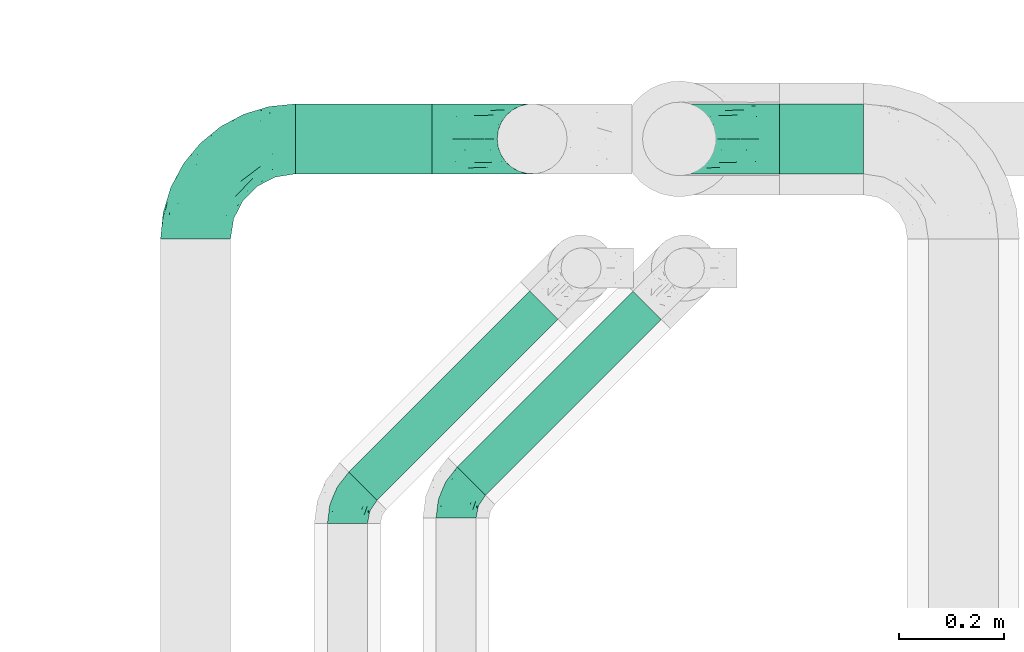
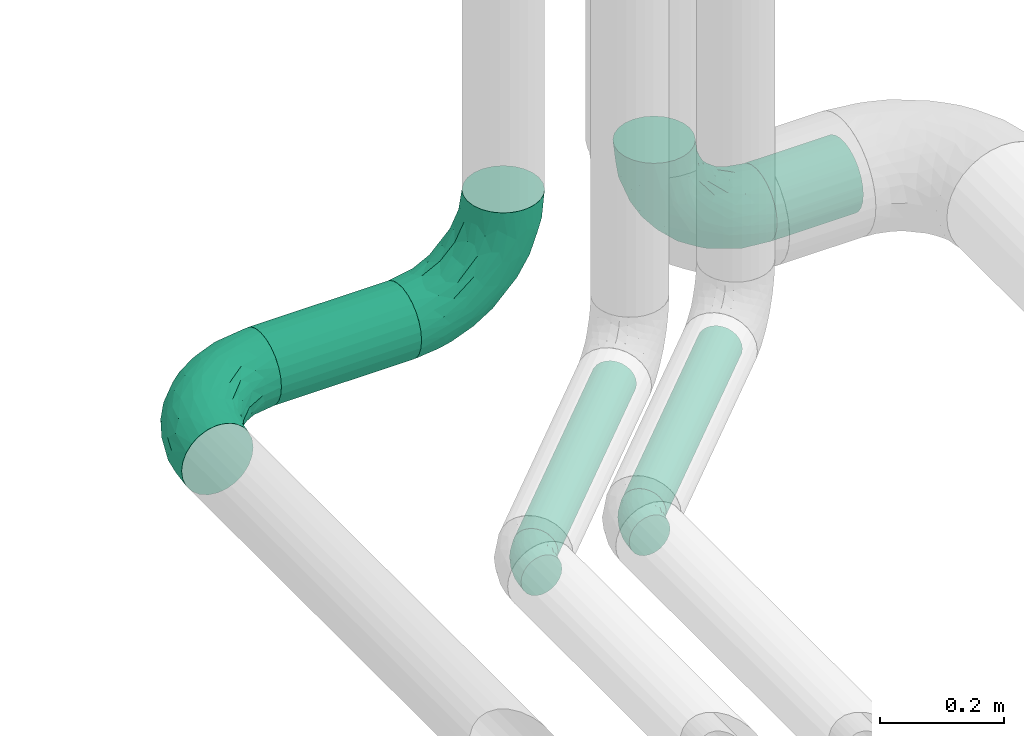
# One storey, part 70 of 93: 5 flow fittings, 4 flow segments.
"""IFC2X3 building model written with IfcOpenShell, lengths in millimetres."""

from ifc_helpers import new_model, entity, si_unit, converted_unit, derived_unit, direction, frame, origin, origin_2d_with_axis, place, context, subcontext, project, spatial, circle, extrude, faceted_brep, source, transform, mapped, material, type_object, type_shapes, element, save


model = new_model("IFC2X3")

# Units and contexts
model_context = context("Model", 3, precision=0.01, world=origin(), true_north=direction((6.12303176911189e-17, 1.0)))
body_context = subcontext(model_context, "Body", "Model", "MODEL_VIEW")
ifc_project = project(units=[si_unit("LENGTHUNIT", "METRE", prefix="MILLI"), si_unit("AREAUNIT", "SQUARE_METRE"), si_unit("VOLUMEUNIT", "CUBIC_METRE"), converted_unit("PLANEANGLEUNIT", "DEGREE", entity("IfcRatioMeasure", 0.0174532925199433), si_unit("PLANEANGLEUNIT", "RADIAN"), dimensions=[0, 0, 0, 0, 0, 0, 0]), si_unit("MASSUNIT", "GRAM", prefix="KILO"), derived_unit("MASSDENSITYUNIT", [(si_unit("MASSUNIT", "GRAM", prefix="KILO"), 1), (si_unit("LENGTHUNIT", "METRE"), -3)]), derived_unit("MOMENTOFINERTIAUNIT", [(si_unit("LENGTHUNIT", "METRE"), 4)]), si_unit("TIMEUNIT", "SECOND"), si_unit("FREQUENCYUNIT", "HERTZ"), si_unit("THERMODYNAMICTEMPERATUREUNIT", "DEGREE_CELSIUS"), derived_unit("THERMALTRANSMITTANCEUNIT", [(si_unit("MASSUNIT", "GRAM", prefix="KILO"), 1), (si_unit("THERMODYNAMICTEMPERATUREUNIT", "KELVIN"), -1), (si_unit("TIMEUNIT", "SECOND"), -3)]), derived_unit("VOLUMETRICFLOWRATEUNIT", [(si_unit("LENGTHUNIT", "METRE"), 3), (si_unit("TIMEUNIT", "SECOND"), -1)]), derived_unit("MASSFLOWRATEUNIT", [(si_unit("MASSUNIT", "GRAM", prefix="KILO"), 1), (si_unit("TIMEUNIT", "SECOND"), -1)]), derived_unit("ROTATIONALFREQUENCYUNIT", [(si_unit("TIMEUNIT", "SECOND"), -1)]), si_unit("ELECTRICCURRENTUNIT", "AMPERE"), si_unit("ELECTRICVOLTAGEUNIT", "VOLT"), si_unit("POWERUNIT", "WATT"), si_unit("FORCEUNIT", "NEWTON", prefix="KILO"), si_unit("ILLUMINANCEUNIT", "LUX"), si_unit("LUMINOUSFLUXUNIT", "LUMEN"), si_unit("LUMINOUSINTENSITYUNIT", "CANDELA"), derived_unit("USERDEFINED", [(si_unit("MASSUNIT", "GRAM", prefix="KILO"), -1), (si_unit("LENGTHUNIT", "METRE"), -2), (si_unit("TIMEUNIT", "SECOND"), 3), (si_unit("LUMINOUSFLUXUNIT", "LUMEN"), 1)]), derived_unit("LINEARVELOCITYUNIT", [(si_unit("LENGTHUNIT", "METRE"), 1), (si_unit("TIMEUNIT", "SECOND"), -1)]), si_unit("PRESSUREUNIT", "PASCAL"), derived_unit("USERDEFINED", [(si_unit("LENGTHUNIT", "METRE"), -2), (si_unit("MASSUNIT", "GRAM", prefix="KILO"), 1), (si_unit("TIMEUNIT", "SECOND"), -2)]), derived_unit("LINEARFORCEUNIT", [(si_unit("MASSUNIT", "GRAM", prefix="KILO"), 1), (si_unit("LENGTHUNIT", "METRE"), 1), (si_unit("TIMEUNIT", "SECOND"), -2), (si_unit("LENGTHUNIT", "METRE"), -1)]), derived_unit("PLANARFORCEUNIT", [(si_unit("MASSUNIT", "GRAM", prefix="KILO"), 1), (si_unit("LENGTHUNIT", "METRE"), 1), (si_unit("TIMEUNIT", "SECOND"), -2), (si_unit("LENGTHUNIT", "METRE"), -2)])], contexts=[model_context])

# Site, building, storey
site_placement = place(None, origin())
site = spatial("IfcSite", under=ifc_project, at=site_placement, CompositionType="ELEMENT")
building_placement = place(site_placement, origin())
building = spatial("IfcBuilding", under=site, at=building_placement, CompositionType="ELEMENT")
storey_placement = place(building_placement, frame((0.0, 0.0, -4200.0)))
storey = spatial("IfcBuildingStorey", under=building, at=storey_placement, CompositionType="ELEMENT", Elevation=-4200.0)

# Flow segments
pipe_segment_type = type_object("IfcPipeSegmentType", PredefinedType="NOTDEFINED")
flow_segment_1_placement = place(storey_placement, frame((25289.12, 12247.47, 2931.9)))
element("IfcFlowSegment", 1, at=flow_segment_1_placement, inside=storey, type_object=pipe_segment_type, context=body_context, shape_type="SweptSolid", body=[
    extrude(circle(Radius=66.5, at=origin_2d_with_axis()), frame((0.0, 68.1, 68.1), z_axis=(1.0, 0.0, 0.0), x_axis=(0.0, 1.0, 0.0)), (0.0, 0.0, 1.0), 159.999999999968),
])
flow_segment_2_placement = place(storey_placement, frame((24369.3, 12247.47, 2932.66)))
element("IfcFlowSegment", 2, at=flow_segment_2_placement, inside=storey, type_object=pipe_segment_type, context=body_context, shape_type="SweptSolid", body=[
    extrude(circle(Radius=66.5, at=origin_2d_with_axis()), frame((0.0, 68.1, 68.1), z_axis=(1.0, 0.0, 0.0), x_axis=(0.0, -1.0, 0.0)), (0.0, 0.0, 1.0), 260.000000000028),
])
flow_segment_3_placement = place(storey_placement, frame((24675.28, 11636.56, 2960.4)))
element("IfcFlowSegment", 3, at=flow_segment_3_placement, inside=storey, type_object=pipe_segment_type, context=body_context, shape_type="SweptSolid", body=[
    extrude(circle(Radius=38.0, at=origin_2d_with_axis()), frame((28.47, 28.47, 39.6), z_axis=(0.707106781186552, 0.707106781186543, 0.0), x_axis=(0.707106781186543, -0.707106781186552, 0.0)), (0.0, 0.0, 1.0), 472.720779386446),
])
flow_segment_4_placement = place(storey_placement, frame((24468.87, 11626.56, 2960.4)))
element("IfcFlowSegment", 4, at=flow_segment_4_placement, inside=storey, type_object=pipe_segment_type, context=body_context, shape_type="SweptSolid", body=[
    extrude(circle(Radius=38.0, at=origin_2d_with_axis()), frame((28.47, 28.47, 39.6), z_axis=(0.707106781186561, 0.707106781186534, 0.0), x_axis=(0.707106781186534, -0.707106781186561, 0.0)), (0.0, 0.0, 1.0), 486.862915010174),
])

# Flow fittings
ifc_material = material()
pipe_fitting_type_1 = type_object("IfcPipeFittingType", Name="ADSK_2", PredefinedType="NOTDEFINED", material=ifc_material)
shared_shape_1 = source(origin(), body_context, "Body", "Brep", [
    faceted_brep([(-190.0, 33.25, -57.59), (-190.0, 17.21, -64.23), (-190.0, 0.0, -66.5), (-190.0, -17.21, -64.23), (-190.0, -33.25, -57.59), (-190.0, -47.02, -47.02), (-190.0, -57.59, -33.25), (-190.0, -64.23, -17.21), (-190.0, -66.5, 0.0), (-190.0, -64.23, 17.21), (-190.0, -57.59, 33.25), (-190.0, -47.02, 47.02), (-190.0, -33.25, 57.59), (-190.0, -17.21, 64.23), (-190.0, 0.0, 66.5), (-190.0, 17.21, 64.23), (-190.0, 33.25, 57.59), (-190.0, 47.02, 47.02), (-190.0, 57.59, 33.25), (-190.0, 64.23, 17.21), (-190.0, 66.5, 0.0), (-190.0, 64.23, -17.21), (-190.0, 57.59, -33.25), (-190.0, 47.02, -47.02), (0.0, 190.0, -66.5), (-17.21, 190.0, -64.23), (-33.25, 190.0, -57.59), (-47.02, 190.0, -47.02), (-57.59, 190.0, -33.25), (-64.23, 190.0, -17.21), (-66.5, 190.0, 0.0), (-64.23, 190.0, 17.21), (-57.59, 190.0, 33.25), (-47.02, 190.0, 47.02), (-33.25, 190.0, 57.59), (-17.21, 190.0, 64.23), (0.0, 190.0, 66.5), (17.21, 190.0, 64.23), (33.25, 190.0, 57.59), (47.02, 190.0, 47.02), (57.59, 190.0, 33.25), (64.23, 190.0, 17.21), (66.5, 190.0, 0.0), (64.23, 190.0, -17.21), (57.59, 190.0, -33.25), (47.02, 190.0, -47.02), (33.25, 190.0, -57.59), (17.21, 190.0, -64.23), (-28.55, 147.02, 62.42), (-13.57, 135.63, 66.28), (-140.38, -49.33, 38.23), (-80.14, -30.55, 35.23), (-124.14, -33.9, 50.4), (-141.11, -22.46, 60.31), (-81.84, -6.19, 57.13), (-101.3, 6.38, 65.03), (-125.04, -54.28, 21.95), (-139.96, -61.57, 0.0), (-30.59, -6.47, 21.28), (-47.5, -23.27, 0.0), (-8.63, 8.63, 0.0), (-101.64, 52.37, 61.01), (-147.02, 28.55, 62.42), (-107.01, 35.47, 64.88), (-72.79, -35.94, 16.05), (-91.84, -46.98, 0.0), (-42.05, -7.73, 34.33), (-4.24, 27.9, 35.0), (-46.26, 0.22, 45.96), (-148.38, -6.74, 65.57), (-135.63, 13.57, 66.28), (-58.81, 143.49, 42.9), (-64.43, 158.86, 27.32), (33.87, 124.03, 50.39), (-24.86, 95.88, 66.5), (-6.38, 101.3, 65.03), (-68.44, 29.45, 65.52), (-33.12, 50.38, 63.42), (-47.55, 58.11, 66.37), (-68.78, 157.93, 15.75), (-78.73, 128.81, 21.25), (-145.19, 58.3, 42.81), (-126.57, 73.12, 34.22), (-158.86, 64.43, 27.32), (-157.93, 68.78, 15.75), (-73.06, 126.96, 34.0), (-99.23, 99.23, 24.99), (-94.51, 94.51, 37.44), (-160.28, 41.89, 53.91), (-151.84, 72.54, 0.0), (-128.81, 78.73, 21.25), (-117.41, 90.09, 0.0), (7.42, 29.34, 16.05), (36.05, 72.53, 15.16), (23.27, 47.5, 0.0), (30.73, 80.34, 35.12), (61.57, 139.96, 0.0), (62.07, 150.38, 13.25), (46.98, 91.84, 0.0), (22.46, 141.08, 60.31), (6.16, 81.82, 57.15), (-39.4, 100.2, 64.86), (54.07, 123.33, 21.27), (49.32, 140.35, 38.22), (-83.36, -19.52, 48.87), (6.74, 148.38, 65.57), (-85.07, 81.39, 53.88), (-123.92, 51.92, 55.31), (-90.09, 117.41, 0.0), (-72.54, 151.84, 0.0), (-101.92, 101.92, 11.85), (-42.36, 157.28, 54.02), (-54.08, 118.94, 55.5), (-1.97, 47.81, 48.28), (22.27, 83.36, 46.49), (-79.1, 73.18, 59.88), (-73.69, 63.3, 64.01), (-96.26, 24.55, 66.5), (-73.56, 111.53, 44.32), (-111.08, 72.88, 45.21), (-31.39, 31.39, 56.96), (-71.89, 12.15, 62.21), (-42.48, 117.92, 61.28), (-157.28, 42.36, -54.02), (-72.79, -35.94, -16.05), (-44.48, -10.39, -33.14), (-30.59, -6.47, -21.28), (-101.3, 6.38, -65.03), (-148.38, -6.74, -65.57), (-135.63, 13.57, -66.28), (-157.93, 68.78, -15.75), (-128.81, 78.73, -21.25), (-158.86, 64.43, -27.32), (-147.02, 28.55, -62.42), (-100.2, 39.4, -64.86), (-95.88, 24.86, -66.5), (-150.3, -62.06, -13.27), (-101.92, 101.92, -11.85), (-143.49, 58.81, -42.9), (6.74, 148.38, -65.57), (-13.57, 135.63, -66.28), (-52.37, 101.64, -61.01), (-81.39, 85.07, -53.88), (-51.92, 123.92, -55.31), (-124.14, -33.9, -50.4), (-81.84, -6.19, -57.13), (-78.6, -18.73, -47.44), (-140.38, -49.33, -38.23), (-24.55, 96.26, -66.5), (-35.47, 107.01, -64.88), (-28.55, 147.02, -62.42), (-80.14, -30.55, -35.23), (-123.37, -54.04, -21.36), (-64.43, 158.86, -27.32), (-68.78, 157.93, -15.75), (-73.18, 79.1, -59.88), (-63.3, 73.69, -64.01), (-29.45, 68.44, -65.52), (-50.38, 33.12, -63.42), (-58.11, 47.55, -66.37), (-78.73, 128.81, -21.25), (-99.23, 99.23, -24.99), (-126.96, 73.06, -34.0), (-94.51, 94.51, -37.44), (-58.3, 145.19, -42.81), (-73.12, 126.57, -34.22), (-118.94, 54.08, -55.5), (-41.89, 160.28, -53.91), (22.46, 141.08, -60.31), (6.16, 81.82, -57.15), (-6.38, 101.3, -65.03), (33.87, 124.03, -50.39), (54.35, 125.32, -21.97), (35.86, 72.99, -16.69), (49.34, 140.46, -38.23), (7.54, 29.16, -15.21), (-141.11, -22.46, -60.31), (30.73, 80.34, -35.12), (22.8, 84.14, -46.35), (-4.38, 23.43, -29.89), (5.33, 47.62, -41.81), (-111.53, 73.56, -44.32), (-72.88, 111.08, -45.21), (-48.51, 2.91, -49.35), (-20.15, 28.66, -49.63), (-27.46, 10.86, -41.59), (-12.16, 71.91, -62.22), (2.48, 58.84, -50.8), (-117.92, 42.48, -61.28), (-31.39, 31.39, -56.96)], [[[0, 1, 2, 3, 4, 5, 6, 7, 8, 9, 10, 11, 12, 13, 14, 15, 16, 17, 18, 19, 20, 21, 22, 23]], [[24, 25, 26, 27, 28, 29, 30, 31, 32, 33, 34, 35, 36, 37, 38, 39, 40, 41, 42, 43, 44, 45, 46, 47]], [[35, 48, 49]], [[50, 51, 52]], [[53, 54, 55]], [[56, 10, 9]], [[9, 8, 57]], [[58, 59, 60]], [[56, 50, 10]], [[61, 62, 63]], [[64, 65, 59]], [[58, 64, 59]], [[12, 11, 52]], [[66, 67, 68]], [[52, 53, 12]], [[69, 70, 14]], [[71, 32, 72]], [[73, 39, 38]], [[49, 74, 75]], [[62, 16, 15]], [[14, 70, 15]], [[72, 32, 31]], [[13, 69, 14]], [[76, 77, 78]], [[79, 80, 72]], [[81, 82, 83]], [[62, 15, 70]], [[20, 19, 84]], [[85, 86, 87]], [[81, 17, 88]], [[89, 90, 91]], [[19, 83, 84]], [[16, 88, 17]], [[85, 71, 72]], [[58, 60, 92]], [[49, 36, 35]], [[93, 92, 94]], [[35, 34, 48]], [[92, 93, 95]], [[96, 97, 98]], [[73, 99, 100]], [[49, 101, 74]], [[102, 97, 40]], [[39, 73, 103]], [[95, 102, 103]], [[40, 39, 103]], [[12, 53, 13]], [[68, 54, 104]], [[42, 97, 96]], [[41, 97, 42]], [[99, 38, 37]], [[37, 36, 105]], [[61, 106, 107]], [[108, 80, 109]], [[10, 50, 11]], [[108, 91, 110]], [[109, 79, 30]], [[64, 51, 56]], [[71, 33, 32]], [[86, 110, 90]], [[92, 60, 94]], [[111, 34, 33]], [[71, 112, 111]], [[49, 48, 101]], [[9, 57, 56]], [[17, 81, 18]], [[65, 56, 57]], [[113, 114, 100]], [[75, 105, 49]], [[115, 61, 116]], [[58, 92, 67]], [[99, 73, 38]], [[70, 117, 63]], [[18, 83, 19]], [[71, 85, 118]], [[119, 107, 106]], [[83, 82, 90]], [[51, 50, 56]], [[52, 11, 50]], [[51, 64, 58]], [[56, 65, 64]], [[94, 98, 93]], [[67, 92, 95]], [[95, 114, 113]], [[68, 120, 54]], [[54, 53, 52]], [[69, 53, 55]], [[104, 51, 68]], [[121, 76, 55]], [[103, 73, 114]], [[102, 40, 103]], [[105, 99, 37]], [[75, 77, 100]], [[75, 100, 99]], [[100, 120, 113]], [[111, 48, 34]], [[115, 101, 122]], [[122, 101, 48]], [[101, 116, 78]], [[116, 63, 117]], [[78, 117, 76]], [[63, 62, 70]], [[88, 62, 107]], [[98, 102, 93]], [[95, 93, 102]], [[66, 68, 51]], [[113, 68, 67]], [[49, 105, 36]], [[99, 105, 75]], [[53, 69, 13]], [[70, 69, 55]], [[70, 55, 117]], [[61, 63, 116]], [[76, 117, 55]], [[116, 117, 78]], [[121, 55, 54]], [[76, 121, 77]], [[100, 77, 120]], [[75, 78, 77]], [[54, 120, 121]], [[77, 121, 120]], [[71, 111, 33]], [[111, 112, 122]], [[68, 113, 120]], [[95, 113, 67]], [[61, 115, 106]], [[62, 61, 107]], [[118, 112, 71]], [[119, 87, 82]], [[101, 115, 116]], [[112, 106, 115]], [[79, 72, 31]], [[72, 80, 85]], [[86, 85, 80]], [[118, 85, 87]], [[119, 118, 87]], [[112, 118, 106]], [[30, 79, 31]], [[109, 80, 79]], [[81, 83, 18]], [[84, 83, 90]], [[119, 82, 81]], [[86, 82, 87]], [[107, 119, 81]], [[118, 119, 106]], [[90, 89, 84]], [[20, 84, 89]], [[62, 88, 16]], [[81, 88, 107]], [[101, 78, 74]], [[78, 75, 74]], [[80, 108, 110]], [[82, 86, 90]], [[90, 110, 91]], [[80, 110, 86]], [[40, 97, 41]], [[98, 97, 102]], [[111, 122, 48]], [[115, 122, 112]], [[54, 52, 104]], [[51, 104, 52]], [[51, 58, 66]], [[67, 66, 58]], [[103, 114, 95]], [[100, 114, 73]], [[23, 123, 0]], [[124, 125, 126]], [[127, 128, 129]], [[130, 131, 132]], [[133, 134, 129]], [[129, 135, 127]], [[89, 130, 20]], [[8, 136, 57]], [[91, 131, 89]], [[59, 65, 124]], [[108, 137, 91]], [[132, 22, 21]], [[138, 23, 22]], [[139, 140, 24]], [[141, 142, 143]], [[144, 145, 146]], [[5, 144, 147]], [[140, 148, 149]], [[8, 7, 136]], [[138, 22, 132]], [[6, 5, 147]], [[141, 150, 149]], [[147, 151, 152]], [[152, 136, 6]], [[29, 153, 154]], [[125, 124, 151]], [[136, 65, 57]], [[155, 141, 156]], [[128, 3, 2]], [[126, 59, 124]], [[129, 134, 135]], [[157, 158, 159]], [[160, 161, 137]], [[1, 0, 133]], [[129, 2, 1]], [[162, 138, 132]], [[161, 163, 162]], [[154, 30, 29]], [[144, 5, 4]], [[153, 164, 165]], [[150, 26, 25]], [[166, 123, 138]], [[24, 47, 139]], [[24, 140, 25]], [[28, 153, 29]], [[26, 167, 27]], [[168, 169, 170]], [[140, 150, 25]], [[27, 164, 28]], [[46, 171, 168]], [[172, 98, 173]], [[59, 126, 60]], [[27, 167, 164]], [[44, 174, 45]], [[173, 98, 94]], [[175, 173, 94]], [[176, 144, 4]], [[171, 46, 45]], [[44, 43, 172]], [[43, 96, 172]], [[42, 96, 43]], [[144, 146, 151]], [[144, 176, 145]], [[177, 178, 174]], [[173, 175, 179]], [[44, 172, 174]], [[98, 172, 96]], [[1, 133, 129]], [[179, 180, 177]], [[109, 160, 108]], [[46, 168, 47]], [[176, 4, 3]], [[138, 162, 181]], [[182, 143, 142]], [[153, 165, 160]], [[94, 60, 175]], [[177, 172, 173]], [[151, 147, 144]], [[152, 6, 147]], [[128, 176, 3]], [[127, 158, 145]], [[127, 145, 176]], [[183, 184, 185]], [[65, 152, 124]], [[151, 124, 152]], [[177, 174, 172]], [[171, 45, 174]], [[169, 168, 171]], [[139, 168, 170]], [[178, 177, 180]], [[186, 157, 170]], [[187, 169, 178]], [[126, 179, 175]], [[123, 133, 0]], [[155, 134, 188]], [[188, 134, 133]], [[134, 156, 159]], [[156, 149, 148]], [[159, 148, 157]], [[149, 150, 140]], [[167, 150, 143]], [[60, 126, 175]], [[125, 179, 126]], [[129, 128, 2]], [[176, 128, 127]], [[168, 139, 47]], [[140, 139, 170]], [[140, 170, 148]], [[141, 149, 156]], [[157, 148, 170]], [[156, 148, 159]], [[186, 170, 169]], [[157, 186, 158]], [[145, 158, 189]], [[127, 159, 158]], [[169, 189, 186]], [[158, 186, 189]], [[180, 179, 185]], [[173, 179, 177]], [[187, 184, 189]], [[178, 171, 174]], [[187, 178, 180]], [[169, 171, 178]], [[184, 180, 185]], [[189, 169, 187]], [[138, 123, 23]], [[123, 166, 188]], [[141, 155, 142]], [[150, 141, 143]], [[181, 166, 138]], [[182, 163, 165]], [[134, 155, 156]], [[166, 142, 155]], [[130, 132, 21]], [[132, 131, 162]], [[161, 162, 131]], [[181, 162, 163]], [[182, 181, 163]], [[166, 181, 142]], [[20, 130, 21]], [[89, 131, 130]], [[164, 153, 28]], [[154, 153, 160]], [[182, 165, 164]], [[161, 165, 163]], [[143, 182, 164]], [[181, 182, 142]], [[160, 109, 154]], [[30, 154, 109]], [[150, 167, 26]], [[164, 167, 143]], [[134, 159, 135]], [[159, 127, 135]], [[131, 91, 137]], [[165, 161, 160]], [[160, 137, 108]], [[131, 137, 161]], [[6, 136, 7]], [[65, 136, 152]], [[183, 189, 184]], [[146, 183, 125]], [[146, 125, 151]], [[179, 125, 185]], [[123, 188, 133]], [[155, 188, 166]], [[180, 184, 187]], [[185, 125, 183]], [[146, 145, 183]], [[189, 183, 145]]]),
])
type_shapes(pipe_fitting_type_1, [shared_shape_1])
for number, where, z_axis, x_axis, name in (
    (5, (24179.3, 12315.57, 3000.76), (0.0, 0.0, 1.0), (-1.0, 0.0, 0.0), "ADSK_2"),
    (6, (25099.12, 12315.57, 3000.0), (0.0, 1.0, 0.0), (-1.0, 0.0, 0.0), "ADSK_2"),
    (7, (24819.3, 12315.57, 3000.76), (0.0, -1.0, 0.0), (1.0, 0.0, 0.0), "ADSK_2"),
):
    element("IfcFlowFitting", number, at=place(storey_placement, frame(where, z_axis=z_axis, x_axis=x_axis)), inside=storey, type_object=pipe_fitting_type_1, material=ifc_material, Name=name, ObjectType="ADSK_2", context=body_context, shape_type="MappedRepresentation", body=[
        mapped(shared_shape_1, transform((0.0, 0.0, 0.0), scale=1.0)),
    ])
pipe_fitting_type_2 = type_object("IfcPipeFittingType", Name="ADSK_2", PredefinedType="NOTDEFINED", material=ifc_material)
shared_shape_2 = source(origin(), body_context, "Body", "Brep", [
    faceted_brep([(-41.42, 19.0, -32.91), (-41.42, 9.84, -36.71), (-41.42, 0.0, -38.0), (-41.42, -9.84, -36.71), (-41.42, -19.0, -32.91), (-41.42, -26.87, -26.87), (-41.42, -32.91, -19.0), (-41.42, -36.71, -9.84), (-41.42, -38.0, 0.0), (-41.42, -36.71, 9.84), (-41.42, -32.91, 19.0), (-41.42, -26.87, 26.87), (-41.42, -19.0, 32.91), (-41.42, -9.84, 36.71), (-41.42, 0.0, 38.0), (-41.42, 9.84, 36.71), (-41.42, 19.0, 32.91), (-41.42, 26.87, 26.87), (-41.42, 32.91, 19.0), (-41.42, 36.71, 9.84), (-41.42, 38.0, 0.0), (-41.42, 36.71, -9.84), (-41.42, 32.91, -19.0), (-41.42, 26.87, -26.87), (29.29, 29.29, -38.0), (22.33, 36.24, -36.71), (15.85, 42.72, -32.91), (10.29, 48.29, -26.87), (6.02, 52.56, -19.0), (3.33, 55.24, -9.84), (2.42, 56.16, 0.0), (3.33, 55.24, 9.84), (6.02, 52.56, 19.0), (10.29, 48.29, 26.87), (15.85, 42.72, 32.91), (22.33, 36.24, 36.71), (29.29, 29.29, 38.0), (36.24, 22.33, 36.71), (42.72, 15.85, 32.91), (48.29, 10.29, 26.87), (52.56, 6.02, 19.0), (55.24, 3.33, 9.84), (56.16, 2.42, 0.0), (55.24, 3.33, -9.84), (52.56, 6.02, -19.0), (48.29, 10.29, -26.87), (42.72, 15.85, -32.91), (36.24, 22.33, -36.71), (-17.7, -28.46, 22.49), (-10.63, -31.95, 13.56), (8.78, -21.19, 21.74), (-22.64, -35.53, 0.0), (-5.7, -33.3, 0.0), (-14.99, -34.84, 6.67), (-12.2, -20.42, 29.53), (32.64, -7.61, 22.49), (5.33, -12.86, 30.87), (-20.91, -13.35, 34.83), (13.48, 21.69, 37.75), (-15.16, -2.57, 37.54), (-4.53, 10.93, 37.83), (-24.87, 5.8, 37.75), (23.06, -5.81, 29.53), (24.22, 5.35, 34.83), (-18.47, 16.84, 35.43), (-11.64, 28.1, 30.86), (11.04, -24.34, 14.9), (11.11, -26.82, 7.43), (-20.72, 32.74, 23.79), (-16.43, 39.68, 15.47), (35.24, -14.04, 6.67), (41.13, -9.11, 0.0), (-17.69, 42.72, 0.0), (12.54, 8.9, 37.54), (2.96, -7.14, 34.48), (-3.5, 40.9, 23.61), (30.11, -15.08, 13.56), (3.4, 26.4, 35.4), (-12.51, 44.21, 7.91), (10.94, -26.4, 0.0), (27.58, -19.51, 0.0), (-15.16, -2.57, -37.54), (-14.99, -34.84, -6.67), (11.1, -26.79, -7.58), (1.15, 24.96, -35.43), (-24.87, 5.8, -37.75), (-16.43, 39.68, -15.47), (23.06, -5.81, -29.53), (-11.64, 28.1, -30.86), (30.11, -15.08, -13.56), (-26.44, 31.39, -23.61), (12.54, 8.9, -37.54), (-22.42, 40.11, -7.91), (-21.07, 16.26, -35.4), (-10.63, -31.95, -13.56), (32.64, -7.61, -22.49), (-17.7, -28.46, -22.49), (8.78, -21.19, -21.74), (-12.2, -20.42, -29.53), (5.33, -12.86, -30.87), (2.96, -7.14, -34.48), (24.22, 5.35, -34.83), (-20.91, -13.35, -34.83), (-8.5, 37.8, -23.79), (35.24, -14.04, -6.67), (13.48, 21.69, -37.75), (-4.53, 10.93, -37.83), (9.16, -25.09, -14.97)], [[[0, 1, 2, 3, 4, 5, 6, 7, 8, 9, 10, 11, 12, 13, 14, 15, 16, 17, 18, 19, 20, 21, 22, 23]], [[24, 25, 26, 27, 28, 29, 30, 31, 32, 33, 34, 35, 36, 37, 38, 39, 40, 41, 42, 43, 44, 45, 46, 47]], [[48, 49, 50]], [[51, 52, 53]], [[12, 11, 54]], [[40, 39, 55]], [[54, 56, 57]], [[48, 11, 10]], [[36, 35, 58]], [[13, 12, 57]], [[59, 60, 61]], [[14, 13, 59]], [[62, 55, 39]], [[38, 37, 63]], [[61, 15, 14]], [[16, 64, 65]], [[9, 51, 53]], [[34, 33, 65]], [[66, 49, 67]], [[65, 17, 16]], [[18, 17, 68]], [[18, 68, 69]], [[19, 18, 69]], [[41, 70, 71]], [[19, 72, 20]], [[52, 67, 53]], [[49, 53, 67]], [[16, 15, 64]], [[36, 58, 73]], [[39, 38, 62]], [[74, 73, 59]], [[73, 37, 36]], [[75, 65, 33]], [[76, 40, 55]], [[60, 58, 77]], [[62, 38, 63]], [[17, 65, 68]], [[70, 41, 76]], [[49, 48, 10]], [[61, 64, 15]], [[56, 50, 62]], [[19, 69, 78]], [[10, 9, 49]], [[72, 78, 30]], [[48, 54, 11]], [[31, 78, 69]], [[74, 63, 73]], [[69, 68, 75]], [[55, 62, 50]], [[32, 75, 33]], [[57, 59, 13]], [[35, 34, 77]], [[77, 65, 64]], [[56, 74, 57]], [[60, 59, 73]], [[76, 41, 40]], [[54, 48, 50]], [[32, 31, 69]], [[76, 55, 50]], [[65, 77, 34]], [[60, 77, 64]], [[54, 57, 12]], [[59, 57, 74]], [[73, 63, 37]], [[63, 74, 56]], [[9, 8, 51]], [[67, 52, 79, 80]], [[9, 53, 49]], [[70, 67, 80]], [[67, 76, 66]], [[71, 70, 80]], [[71, 42, 41]], [[67, 70, 76]], [[59, 61, 14]], [[64, 61, 60]], [[77, 58, 35]], [[73, 58, 60]], [[69, 75, 32]], [[65, 75, 68]], [[30, 78, 31]], [[19, 78, 72]], [[50, 56, 54]], [[63, 56, 62]], [[76, 50, 66]], [[49, 66, 50]], [[3, 2, 81]], [[52, 82, 83]], [[26, 25, 84]], [[2, 1, 85]], [[86, 22, 21]], [[46, 45, 87]], [[88, 0, 23]], [[44, 43, 89]], [[22, 90, 23]], [[24, 47, 91]], [[86, 21, 92]], [[1, 0, 93]], [[82, 7, 94]], [[89, 95, 44]], [[94, 96, 97]], [[96, 94, 6]], [[5, 4, 98]], [[99, 100, 101]], [[7, 6, 94]], [[5, 96, 6]], [[102, 4, 3]], [[90, 88, 23]], [[98, 96, 5]], [[28, 27, 103]], [[20, 72, 92]], [[27, 88, 103]], [[72, 30, 29]], [[99, 97, 98]], [[88, 84, 93]], [[28, 86, 29]], [[27, 26, 88]], [[102, 98, 4]], [[84, 88, 26]], [[103, 90, 86]], [[85, 81, 2]], [[103, 86, 28]], [[43, 71, 104]], [[105, 25, 24]], [[101, 47, 46]], [[7, 82, 51]], [[44, 95, 45]], [[101, 87, 99]], [[95, 87, 45]], [[106, 105, 91]], [[97, 95, 89]], [[106, 91, 81]], [[104, 71, 80]], [[101, 91, 47]], [[100, 102, 81]], [[82, 94, 83]], [[100, 81, 91]], [[107, 89, 83]], [[105, 84, 25]], [[29, 86, 92]], [[106, 85, 93]], [[96, 98, 97]], [[87, 95, 97]], [[88, 93, 0]], [[106, 93, 84]], [[81, 102, 3]], [[102, 100, 99]], [[87, 101, 46]], [[91, 101, 100]], [[51, 82, 52]], [[51, 8, 7]], [[107, 83, 94]], [[104, 83, 89]], [[83, 80, 79, 52]], [[43, 42, 71]], [[83, 104, 80]], [[43, 104, 89]], [[93, 85, 1]], [[81, 85, 106]], [[91, 105, 24]], [[84, 105, 106]], [[86, 90, 22]], [[88, 90, 103]], [[20, 92, 21]], [[29, 92, 72]], [[97, 99, 87]], [[102, 99, 98]], [[94, 97, 107]], [[89, 107, 97]]]),
])
type_shapes(pipe_fitting_type_2, [shared_shape_2])
for number, where, z_axis, x_axis, name in (
    (8, (24674.46, 11635.74, 3000.0), (0.0, 0.0, 1.0), (-0.707106781186549, -0.707106781186546, 0.0), "ADSK_2"),
    (9, (24468.05, 11625.74, 3000.0), (0.0, 0.0, 1.0), (-0.707106781186549, -0.707106781186546, 0.0), "ADSK_2"),
):
    element("IfcFlowFitting", number, at=place(storey_placement, frame(where, z_axis=z_axis, x_axis=x_axis)), inside=storey, type_object=pipe_fitting_type_2, material=ifc_material, Name=name, ObjectType="ADSK_2", context=body_context, shape_type="MappedRepresentation", body=[
        mapped(shared_shape_2, transform((0.0, 0.0, 0.0), scale=1.0)),
    ])

save(model, "model.ifc")
